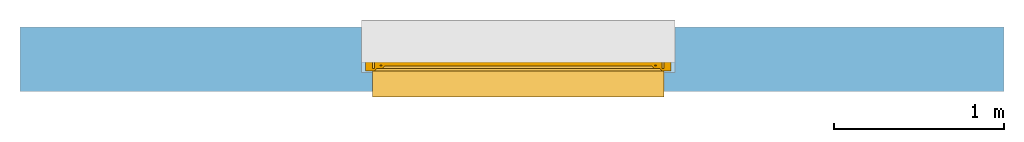
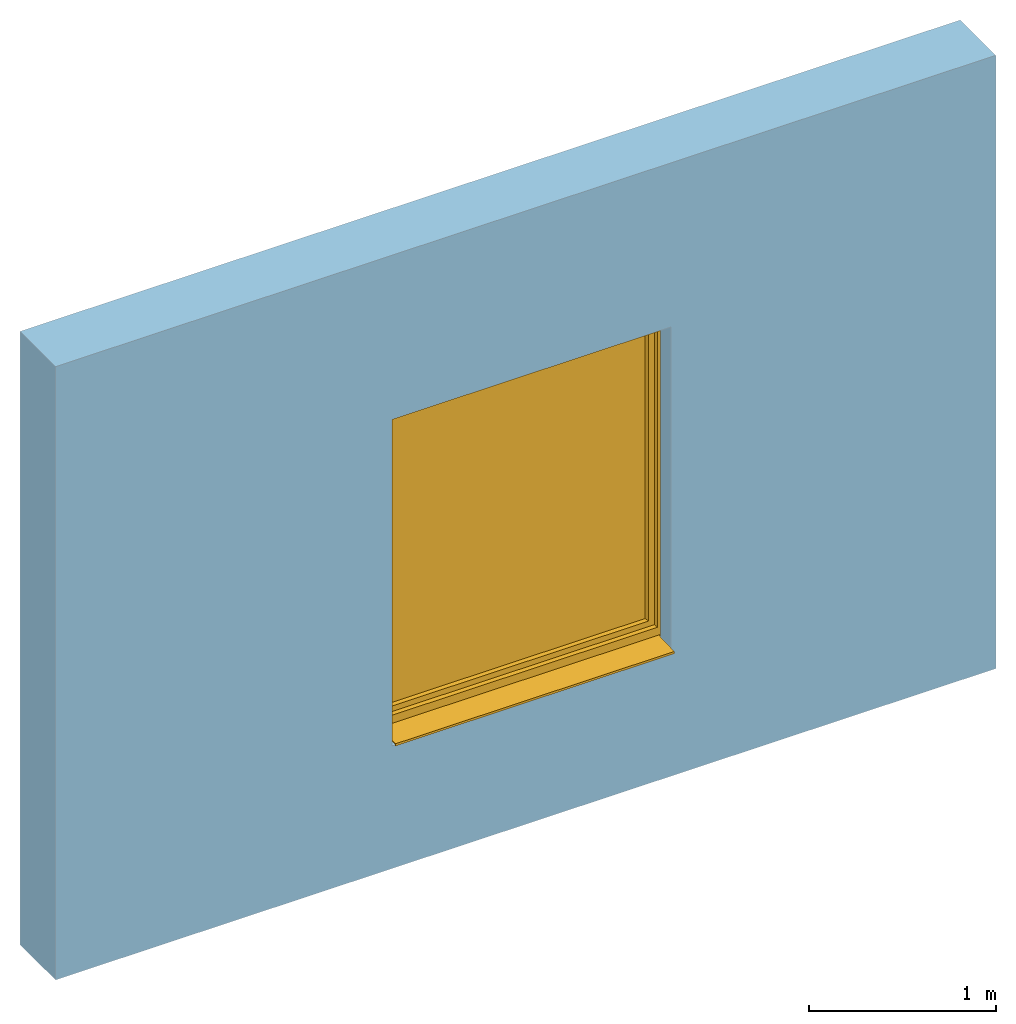
# One storey, part 2 of 3: 1 window, 1 opening, plus 1 element that does not belong to this part.
"""IFC2X3 building model written with IfcOpenShell, lengths in millimetres."""

from ifc_helpers import new_model, entity, si_unit, converted_unit, derived_unit, direction, frame, frame_2d, origin, place, context, subcontext, project, spatial, rectangle, extrude, faceted_brep, source, transform, mapped, material, material_list, layer, layer_set, layer_usage, type_object, type_shapes, element, fill, save


model = new_model("IFC2X3")

# Units and contexts
model_context = context("Model", 3, precision=0.01, world=origin(), true_north=direction((6.12303176911189e-17, 1.0)))
context_of_model = context(None, 3, precision=0.01, world=origin(), true_north=direction((6.12303176911189e-17, 1.0)))
body_context = subcontext(model_context, "Body", "Model", "MODEL_VIEW")
ifc_project = project(units=[si_unit("LENGTHUNIT", "METRE", prefix="MILLI"), si_unit("AREAUNIT", "SQUARE_METRE"), si_unit("VOLUMEUNIT", "CUBIC_METRE"), converted_unit("PLANEANGLEUNIT", "DEGREE", entity("IfcRatioMeasure", 0.0174532925199433), si_unit("PLANEANGLEUNIT", "RADIAN"), dimensions=[0, 0, 0, 0, 0, 0, 0]), si_unit("MASSUNIT", "GRAM", prefix="KILO"), si_unit("TIMEUNIT", "SECOND"), si_unit("FREQUENCYUNIT", "HERTZ"), si_unit("THERMODYNAMICTEMPERATUREUNIT", "DEGREE_CELSIUS"), derived_unit("THERMALTRANSMITTANCEUNIT", [(si_unit("MASSUNIT", "GRAM", prefix="KILO"), 1), (si_unit("THERMODYNAMICTEMPERATUREUNIT", "KELVIN"), -1), (si_unit("TIMEUNIT", "SECOND"), -3)]), derived_unit("VOLUMETRICFLOWRATEUNIT", [(si_unit("LENGTHUNIT", "METRE"), 3), (si_unit("TIMEUNIT", "SECOND"), -1)]), si_unit("ELECTRICCURRENTUNIT", "AMPERE"), si_unit("ELECTRICVOLTAGEUNIT", "VOLT"), si_unit("POWERUNIT", "WATT"), si_unit("FORCEUNIT", "NEWTON", prefix="KILO"), si_unit("ILLUMINANCEUNIT", "LUX"), si_unit("LUMINOUSFLUXUNIT", "LUMEN"), si_unit("LUMINOUSINTENSITYUNIT", "CANDELA"), si_unit("PRESSUREUNIT", "PASCAL")], contexts=[model_context, context_of_model])

# Site, building, storey
site_placement = place(None, origin())
site = spatial("IfcSite", under=ifc_project, at=site_placement, CompositionType="ELEMENT")
building_placement = place(site_placement, origin())
building = spatial("IfcBuilding", under=site, at=building_placement, CompositionType="ELEMENT")
storey_placement = place(building_placement, origin())
storey = spatial("IfcBuildingStorey", under=building, at=storey_placement, CompositionType="ELEMENT", Elevation=0.0)

# Wall, opening, window
ifc_material_1 = material()
ifc_layer = layer(ifc_material_1, 380.0)
ifc_layer_set = layer_set([ifc_layer])
ifc_layer_usage = layer_usage(ifc_layer_set, "AXIS2", "NEGATIVE", 190.0)
wall_type = type_object("IfcWallType", PredefinedType="STANDARD", material=ifc_layer_set)
wall_placement = place(storey_placement, frame((-18279.8270290102, 12543.5585138251, 0.0)))
wall = element("IfcWallStandardCase", 1, at=wall_placement, inside=storey, type_object=wall_type, material=ifc_layer_usage, context=body_context, shape_type="SweptSolid", body=[
    extrude(rectangle(XDim=5800.0, YDim=380.0, at=frame_2d((2900.0, 0.0), x_axis=(-1.0, 0.0))), origin(), (0.0, 0.0, 1.0), 4000.0),
])
opening_placement = place(wall_placement, frame((2011.78748304286, -570.0, 800.0)))
opening = element("IfcOpeningElement", 2, at=opening_placement, cuts=wall, ObjectType="Opening", context=body_context, shape_type="Brep", body=[
    faceted_brep([(1850.0, 1490.0, 2195.0), (1850.0, 1490.0, 0.0), (0.0, 1490.0, 0.0), (0.0, 1490.0, 2195.0), (1850.0, 490.0, 2195.0), (0.0, 490.0, 2195.0), (0.0, 490.0, 0.0), (65.0, 490.0, 0.0), (65.0, 490.0, 2130.0), (1785.0, 490.0, 2130.0), (1785.0, 490.0, 0.0), (1850.0, 490.0, 0.0), (1785.0, 0.0, 0.0), (65.0, 0.0, 0.0), (1785.0, 0.0, 2130.0), (65.0, 0.0, 2130.0)], [[[0, 1, 2, 3]], [[4, 5, 6, 7, 8, 9, 10, 11]], [[3, 5, 4, 0]], [[2, 6, 5, 3]], [[1, 11, 10, 12, 13, 7, 6, 2]], [[0, 4, 11, 1]], [[14, 15, 13, 12]], [[14, 9, 8, 15]], [[15, 8, 7, 13]], [[12, 10, 9, 14]]]),
])
ifc_material_2 = material()
ifc_material_3 = material()
ifc_material_4 = material()
ifc_material_5 = material()
ifc_material_list_1 = material_list([ifc_material_2, ifc_material_3, ifc_material_4, ifc_material_5])
ifc_material_list_2 = material_list([ifc_material_2, ifc_material_3, ifc_material_4, ifc_material_5])
window_style = type_object("IfcWindowStyle", ConstructionType="NOTDEFINED", OperationType="NOTDEFINED", ParameterTakesPrecedence=False, Sizeable=False, material=ifc_material_list_2)
shared_shape = source(origin(), body_context, "Body", "Brep", [
    faceted_brep([(1766.0, 895.0, 1128.0), (1766.0, 895.0, 1092.0), (1766.0, 903.0, 1092.0), (1766.0, 903.0, 1128.0), (1765.15676402479, 903.0, 1132.78534851353), (1765.57778161414, 895.0, 1130.39432433823), (1760.86155337324, 895.0, 1138.56228263261), (1759.00202746121, 903.0, 1140.12318487166), (1758.99898619598, 895.0, 1140.12494091649), (1743.13844662676, 903.0, 1138.56228263261), (1744.9979725388, 895.0, 1140.12318487166), (1745.00101380402, 903.0, 1140.12494091649), (1762.7263777273, 903.0, 1136.99693396949), (1762.7241205505, 895.0, 1136.99962434874), (1763.9398418894, 895.0, 1134.89413651259), (1754.432995843, 903.0, 1141.78696961729), (1754.42953736881, 895.0, 1141.78757948929), (1756.7142617824, 895.0, 1140.95626020289), (1760.86420259425, 903.0, 1138.56005942058), (1765.15556322829, 895.0, 1132.78864867645), (1763.94157087605, 903.0, 1134.89114124151), (1756.7175116521, 903.0, 1140.95507724448), (1749.57046263119, 903.0, 1141.78757948929), (1749.567004157, 895.0, 1141.78696961729), (1751.99827076291, 895.0, 1141.78727455329), (1747.2824883479, 895.0, 1140.95507724448), (1747.2857382176, 903.0, 1140.95626020289), (1740.05842912395, 895.0, 1134.89114124151), (1738.84443677171, 903.0, 1132.78864867645), (1738.84323597521, 895.0, 1132.78534851353), (1741.2758794495, 903.0, 1136.99962434874), (1741.2736222727, 895.0, 1136.99693396949), (1743.13579740575, 895.0, 1138.56005942058), (1752.0017292371, 903.0, 1141.78727455329), (1738.0, 895.0, 1128.0), (1738.42221838586, 903.0, 1130.39432433823), (1738.0, 903.0, 1128.0), (1740.06015811061, 903.0, 1134.89413651259), (1738.0, 895.0, 1092.0), (1738.0, 903.0, 1092.0), (1738.84323597521, 895.0, 1087.21465148645), (1738.84323597521, 903.0, 1087.21465148645), (1744.9979725388, 895.0, 1079.87681512831), (1743.13579740575, 895.0, 1081.4399405794), (1741.2736222727, 895.0, 1083.00306603049), (1741.2736222727, 903.0, 1083.00306603049), (1743.13579740575, 903.0, 1081.4399405794), (1744.9979725388, 903.0, 1079.87681512831), (1765.57778161414, 895.0, 1089.60567566175), (1765.15556322829, 895.0, 1087.21135132352), (1765.15556322829, 903.0, 1087.21135132352), (1765.56908263974, 903.0, 1089.55634534637), (1740.05842912395, 903.0, 1085.10885875847), (1740.05842912395, 895.0, 1085.10885875847), (1747.2824883479, 903.0, 1079.0449227555), (1749.567004157, 903.0, 1078.21303038269), (1749.567004157, 895.0, 1078.21303038269), (1747.2824883479, 895.0, 1079.0449227555), (1754.42953736881, 895.0, 1078.21242051068), (1751.9982707629, 895.0, 1078.21272544669), (1751.9982707629, 903.0, 1078.21272544669), (1754.42953736881, 903.0, 1078.21242051068), (1756.7142617824, 903.0, 1079.04373979708), (1758.99898619598, 903.0, 1079.87505908348), (1758.99898619598, 895.0, 1079.87505908348), (1756.7142617824, 895.0, 1079.04373979708), (1760.86155337324, 903.0, 1081.43771736736), (1762.7241205505, 903.0, 1083.00037565124), (1762.7241205505, 895.0, 1083.00037565124), (1760.86155337324, 895.0, 1081.43771736736), (1763.9398418894, 903.0, 1085.10586348738), (1763.9398418894, 895.0, 1085.10586348738), (1742.63603896932, 893.0, 1134.36396103068), (1741.75735931288, 893.0, 1132.24264068712), (1740.87867965644, 893.0, 1130.12132034356), (1740.0, 893.0, 1128.0), (1740.0, 893.0, 1092.0), (1740.87867965644, 893.0, 1089.87867965642), (1741.75735931288, 893.0, 1087.75735931286), (1742.63603896932, 893.0, 1085.6360389693), (1743.51471862576, 893.0, 1083.51471862574), (1745.63603896932, 893.0, 1082.6360389693), (1747.75735931288, 893.0, 1081.75735931286), (1749.87867965644, 893.0, 1080.87867965642), (1752.0, 893.0, 1080.0), (1754.12132034356, 893.0, 1080.87867965642), (1756.24264068712, 893.0, 1081.75735931286), (1758.36396103068, 893.0, 1082.6360389693), (1760.48528137424, 893.0, 1083.51471862574), (1761.36396103068, 893.0, 1085.6360389693), (1762.24264068712, 893.0, 1087.75735931286), (1763.12132034356, 893.0, 1089.87867965642), (1764.0, 893.0, 1092.0), (1764.0, 893.0, 1128.0), (1763.12132034356, 893.0, 1130.12132034356), (1762.24264068712, 893.0, 1132.24264068712), (1761.36396103068, 893.0, 1134.36396103068), (1760.48528137424, 893.0, 1136.48528137424), (1758.36396103068, 893.0, 1137.36396103068), (1756.24264068712, 893.0, 1138.24264068712), (1754.12132034356, 893.0, 1139.12132034356), (1752.0, 893.0, 1140.0), (1749.87867965644, 893.0, 1139.12132034356), (1747.75735931288, 893.0, 1138.24264068712), (1745.63603896932, 893.0, 1137.36396103068), (1743.51471862576, 893.0, 1136.48528137424), (1740.0, 905.0, 1128.0), (1740.87867965644, 905.0, 1130.12132034356), (1741.75735931288, 905.0, 1132.24264068712), (1742.63603896932, 905.0, 1134.36396103068), (1743.51471862576, 905.0, 1136.48528137424), (1745.63603896932, 905.0, 1137.36396103068), (1747.75735931288, 905.0, 1138.24264068712), (1749.87867965644, 905.0, 1139.12132034356), (1752.0, 905.0, 1140.0), (1754.12132034356, 905.0, 1139.12132034356), (1756.24264068712, 905.0, 1138.24264068712), (1758.36396103068, 905.0, 1137.36396103068), (1760.48528137424, 905.0, 1136.48528137424), (1761.36396103068, 905.0, 1134.36396103068), (1762.24264068712, 905.0, 1132.24264068712), (1763.12132034356, 905.0, 1130.12132034356), (1764.0, 905.0, 1128.0), (1764.0, 905.0, 1092.0), (1763.12132034356, 905.0, 1089.87867965642), (1762.24264068712, 905.0, 1087.75735931286), (1761.36396103068, 905.0, 1085.6360389693), (1760.48528137424, 905.0, 1083.51471862574), (1758.36396103068, 905.0, 1082.6360389693), (1756.24264068712, 905.0, 1081.75735931286), (1754.12132034356, 905.0, 1080.87867965642), (1752.0, 905.0, 1080.0), (1749.87867965644, 905.0, 1080.87867965642), (1747.75735931288, 905.0, 1081.75735931286), (1745.63603896932, 905.0, 1082.6360389693), (1743.51471862576, 905.0, 1083.51471862574), (1742.63603896932, 905.0, 1085.6360389693), (1741.75735931288, 905.0, 1087.75735931286), (1740.87867965644, 905.0, 1089.87867965642), (1740.0, 905.0, 1092.0)], [[[0, 1, 2, 3]], [[4, 5, 3]], [[6, 7, 8]], [[9, 10, 11]], [[12, 13, 14]], [[15, 16, 17]], [[7, 6, 18]], [[5, 0, 3]], [[18, 6, 13]], [[14, 19, 20]], [[4, 19, 5]], [[15, 17, 21]], [[8, 21, 17]], [[12, 14, 20]], [[22, 23, 24]], [[25, 11, 10]], [[26, 23, 22]], [[27, 28, 29]], [[21, 8, 7]], [[20, 19, 4]], [[30, 31, 32]], [[33, 16, 15]], [[34, 35, 36]], [[11, 25, 26]], [[23, 26, 25]], [[37, 27, 31]], [[32, 10, 9]], [[29, 28, 35]], [[30, 32, 9]], [[34, 29, 35]], [[28, 27, 37]], [[18, 13, 12]], [[33, 24, 16]], [[37, 31, 30]], [[22, 24, 33]], [[38, 34, 36, 39]], [[40, 38, 39, 41]], [[42, 43, 44, 45, 46, 47]], [[2, 1, 48, 49, 50, 51]], [[41, 52, 45, 44, 53, 40]], [[47, 54, 55, 56, 57, 42]], [[58, 59, 56, 55, 60, 61]], [[61, 62, 63, 64, 65, 58]], [[66, 67, 68, 69, 64, 63]], [[67, 70, 50, 49, 71, 68]], [[72, 73, 74, 75, 76, 77, 78, 79, 80, 81, 82, 83, 84, 85, 86, 87, 88, 89, 90, 91, 92, 93, 94, 95, 96, 97, 98, 99, 100, 101, 102, 103, 104, 105]], [[92, 48, 1]], [[48, 92, 91]], [[71, 49, 90]], [[44, 79, 53]], [[90, 49, 91]], [[78, 40, 53]], [[88, 68, 89]], [[88, 69, 68]], [[69, 87, 64]], [[89, 68, 71]], [[82, 57, 83]], [[91, 49, 48]], [[65, 85, 58]], [[82, 42, 57]], [[56, 84, 83]], [[65, 64, 86]], [[56, 83, 57]], [[76, 38, 77]], [[58, 84, 56, 59]], [[80, 44, 43]], [[85, 65, 86]], [[40, 77, 38]], [[82, 81, 42]], [[40, 78, 77]], [[43, 81, 80]], [[71, 90, 89]], [[87, 69, 88]], [[79, 44, 80]], [[79, 78, 53]], [[87, 86, 64]], [[85, 84, 58]], [[43, 42, 81]], [[92, 1, 0, 93]], [[72, 31, 27]], [[34, 74, 29]], [[27, 29, 73]], [[13, 96, 14]], [[74, 73, 29]], [[95, 19, 14]], [[104, 32, 105]], [[105, 32, 31]], [[32, 104, 10]], [[105, 31, 72]], [[99, 17, 100]], [[74, 34, 75]], [[25, 102, 23]], [[99, 8, 17]], [[16, 101, 100]], [[25, 10, 103]], [[16, 100, 17]], [[5, 93, 0]], [[99, 98, 8]], [[97, 13, 6]], [[93, 5, 94]], [[102, 25, 103]], [[94, 5, 19]], [[24, 23, 101, 16]], [[27, 73, 72]], [[96, 13, 97]], [[6, 98, 97]], [[96, 95, 14]], [[104, 103, 10]], [[102, 101, 23]], [[6, 8, 98]], [[94, 19, 95]], [[75, 34, 38, 76]], [[106, 107, 108, 109, 110, 111, 112, 113, 114, 115, 116, 117, 118, 119, 120, 121, 122, 123, 124, 125, 126, 127, 128, 129, 130, 131, 132, 133, 134, 135, 136, 137, 138, 139]], [[136, 45, 52]], [[39, 138, 41]], [[52, 41, 137]], [[67, 126, 70]], [[138, 137, 41]], [[125, 50, 70]], [[134, 46, 135]], [[135, 46, 45]], [[46, 134, 47]], [[135, 45, 136]], [[129, 62, 130]], [[138, 39, 139]], [[54, 132, 55]], [[129, 63, 62]], [[61, 131, 130]], [[54, 47, 133]], [[61, 130, 62]], [[51, 123, 2]], [[129, 128, 63]], [[127, 67, 66]], [[123, 51, 124]], [[132, 54, 133]], [[124, 51, 50]], [[60, 55, 131, 61]], [[52, 137, 136]], [[126, 67, 127]], [[66, 128, 127]], [[126, 125, 70]], [[134, 133, 47]], [[132, 131, 55]], [[66, 63, 128]], [[124, 50, 125]], [[122, 3, 2, 123]], [[119, 12, 20]], [[3, 121, 4]], [[20, 4, 120]], [[30, 109, 37]], [[121, 120, 4]], [[108, 28, 37]], [[117, 18, 118]], [[118, 18, 12]], [[18, 117, 7]], [[118, 12, 119]], [[112, 26, 113]], [[121, 3, 122]], [[21, 115, 15]], [[112, 11, 26]], [[22, 114, 113]], [[21, 7, 116]], [[22, 113, 26]], [[35, 106, 36]], [[112, 111, 11]], [[110, 30, 9]], [[106, 35, 107]], [[115, 21, 116]], [[107, 35, 28]], [[33, 15, 114, 22]], [[20, 120, 119]], [[109, 30, 110]], [[9, 111, 110]], [[109, 108, 37]], [[117, 116, 7]], [[115, 114, 15]], [[9, 11, 111]], [[107, 28, 108]], [[139, 39, 36, 106]]]),
    faceted_brep([(1746.70849737789, 844.723224744637, 1050.52114796614), (1757.29150262215, 844.723224744635, 1050.52114796615), (1757.29150262215, 849.16211476527, 1092.66882878316), (1746.70849737789, 849.162114765271, 1092.66882878316), (1759.48331477357, 853.551651869381, 1050.52114796614), (1759.48331477357, 857.796844327507, 1090.82965209671), (1752.0, 858.723224744636, 1050.52114796614), (1752.0, 862.854951797642, 1089.75228733739), (1744.51668522647, 853.551651869382, 1050.52114796614), (1744.51668522647, 857.796844327508, 1090.82965209671), (1746.70849737789, 849.162114765271, 1008.37346714913), (1757.29150262215, 849.162114765269, 1008.37346714913), (1759.48331477357, 857.796844327506, 1010.21264383558), (1752.0, 862.854951797641, 1011.2900085949), (1744.51668522647, 857.796844327507, 1010.21264383558)], [[[0, 1, 2, 3]], [[1, 4, 5, 2]], [[4, 6, 7, 5]], [[6, 8, 9, 7]], [[8, 0, 3, 9]], [[10, 11, 1, 0]], [[11, 12, 4, 1]], [[12, 13, 6, 4]], [[13, 14, 8, 6]], [[14, 10, 0, 8]], [[3, 2, 5, 7, 9]], [[14, 13, 12, 11, 10]]]),
    faceted_brep([(1742.05108068303, 893.0, 1110.94591729899), (1742.6116955587, 893.0, 1113.43924096905), (1743.78926206305, 893.0, 1115.70333478469), (1745.50517385399, 893.0, 1117.59726390533), (1747.64110105648, 893.0, 1119.0), (1752.0, 893.0, 1119.0), (1756.35889894356, 893.0, 1119.0), (1758.49482614605, 893.0, 1117.59726390533), (1760.21073793698, 893.0, 1115.70333478469), (1761.38830444134, 893.0, 1113.43924096905), (1761.94891931701, 893.0, 1110.94591729899), (1761.86909546584, 893.0, 1108.39192032138), (1761.13720137139, 893.0, 1105.94604186492), (1759.80945551189, 893.0, 1103.76141304128), (1757.97703479258, 893.0, 1101.98307257926), (1755.74800577773, 893.0, 1100.73512735944), (1753.27629940962, 893.0, 1100.08403873225), (1750.72370059042, 893.0, 1100.08403873225), (1748.25199422231, 893.0, 1100.73512735944), (1746.02296520745, 893.0, 1101.98307257926), (1744.19054448815, 893.0, 1103.76141304128), (1742.86279862864, 893.0, 1105.94604186492), (1742.13090453419, 893.0, 1108.39192032138), (1745.36991581395, 850.428800129017, 1091.81582813481), (1744.45534262368, 851.933218860195, 1090.80273507334), (1744.03032959918, 853.579532805258, 1089.69408812539), (1744.11827066873, 855.263398076631, 1088.5601536778), (1744.7119819839, 856.873838872368, 1087.47566412561), (1745.77997796969, 858.307181915726, 1086.51043425852), (1747.2448781787, 859.474223513841, 1085.72453488024), (1749.01896983583, 860.293497882239, 1085.17282599702), (1750.98499562504, 860.719017712997, 1084.88627599659), (1753.01500437499, 860.719017712997, 1084.88627599659), (1754.9810301642, 860.293497882239, 1085.17282599702), (1756.75512182133, 859.474223513841, 1085.72453488024), (1758.22002203034, 858.307181915725, 1086.51043425852), (1759.28801801613, 856.873838872367, 1087.47566412561), (1759.88172933131, 855.26339807663, 1088.5601536778), (1759.96967040085, 853.579532805258, 1089.69408812539), (1759.54465737635, 851.933218860195, 1090.80273507334), (1758.63008418608, 850.428800129017, 1091.81582813481), (1757.29150262215, 849.161332807104, 1092.66935536288), (1753.79310555172, 849.161332807104, 1092.66935536288), (1750.2508014648, 849.161332807105, 1092.66935536288), (1746.70849737789, 849.161332807105, 1092.66935536288), (1754.52949888047, 863.583676958992, 1108.5347916618), (1752.0, 866.407496256042, 1110.46960324717), (1752.02195286218, 856.06904422149, 1101.86725150296), (1757.17259060864, 853.432156174798, 1097.74862550588), (1754.75377578685, 855.997000236909, 1101.79007956709), (1749.62092495289, 862.432874221678, 1107.66721198753), (1749.76284265702, 870.821838386956, 1113.00337884313), (1747.01936527075, 860.32641042986, 1105.94792966368), (1749.15805318919, 855.078190113582, 1100.77853435748), (1750.96832520456, 879.059260831814, 1116.41174131505), (1747.33023316361, 875.432522578079, 1115.10298096759), (1754.09205911857, 883.083385469991, 1117.54270145075), (1756.98063472928, 860.32641042986, 1105.94792966368), (1756.66976683642, 875.432522578079, 1115.10298096759), (1760.33445262989, 860.924208850645, 1095.92276589619), (1760.86792617061, 873.480157500358, 1108.07942490607), (1761.45909914595, 882.759427033562, 1110.08550854291), (1755.91403231325, 864.739374449817, 1090.68801313959), (1757.61971635533, 869.555744991712, 1095.78506579301), (1745.02520991073, 866.744726380615, 1095.70424775684), (1742.98228348089, 874.898493111577, 1108.22389640407), (1745.18111717899, 877.977562710016, 1100.92399318818), (1758.84403415027, 880.582594774287, 1101.67364545899), (1760.7354074063, 866.455644046918, 1102.17506192795), (1742.69314957983, 883.881036137867, 1106.84627828436), (1749.47019846674, 885.315312440967, 1099.97313305254)], [[[0, 1, 2, 3, 4, 5, 6, 7, 8, 9, 10, 11, 12, 13, 14, 15, 16, 17, 18, 19, 20, 21, 22]], [[23, 24, 25, 26, 27, 28, 29, 30, 31, 32, 33, 34, 35, 36, 37, 38, 39, 40, 41, 42, 43, 44]], [[45, 46, 47]], [[42, 41, 48]], [[49, 45, 47]], [[50, 46, 51]], [[50, 51, 52]], [[43, 47, 53]], [[53, 50, 52]], [[54, 4, 55]], [[44, 43, 53]], [[56, 6, 5]], [[48, 49, 42]], [[42, 47, 43]], [[49, 48, 57]], [[5, 54, 56]], [[49, 57, 45]], [[42, 49, 47]], [[57, 58, 45]], [[58, 46, 45]], [[50, 47, 46]], [[44, 53, 52]], [[47, 50, 53]], [[46, 54, 51]], [[56, 46, 58]], [[4, 54, 5]], [[54, 55, 51]], [[52, 51, 55]], [[46, 56, 54]], [[6, 56, 58]], [[40, 59, 41]], [[39, 38, 59]], [[59, 40, 39]], [[36, 59, 37]], [[60, 61, 58]], [[35, 34, 62]], [[62, 59, 36]], [[59, 62, 63]], [[33, 62, 34]], [[35, 62, 36]], [[38, 37, 59]], [[9, 8, 61]], [[61, 10, 9]], [[64, 65, 66]], [[8, 7, 61]], [[58, 7, 6]], [[58, 61, 7]], [[63, 67, 68]], [[67, 13, 61]], [[52, 55, 65]], [[67, 60, 68]], [[31, 62, 32]], [[59, 68, 57]], [[13, 67, 14]], [[65, 69, 66]], [[10, 61, 11]], [[11, 61, 12]], [[69, 55, 1]], [[16, 70, 17]], [[33, 32, 62]], [[66, 67, 63]], [[69, 70, 66]], [[67, 66, 70]], [[70, 15, 67]], [[29, 64, 30]], [[27, 64, 28]], [[64, 29, 28]], [[65, 64, 52]], [[25, 24, 64]], [[57, 60, 58]], [[64, 24, 52]], [[23, 44, 52]], [[67, 61, 60]], [[23, 52, 24]], [[64, 26, 25]], [[69, 65, 55]], [[63, 64, 66]], [[69, 20, 19]], [[69, 21, 20]], [[61, 13, 12]], [[60, 57, 68]], [[70, 16, 15]], [[17, 70, 18]], [[68, 59, 63]], [[62, 64, 63]], [[19, 18, 70]], [[69, 1, 0]], [[0, 22, 69]], [[1, 55, 2]], [[30, 62, 31]], [[64, 27, 26]], [[3, 2, 55]], [[4, 3, 55]], [[19, 70, 69]], [[15, 14, 67]], [[21, 69, 22]], [[59, 57, 48, 41]], [[64, 62, 30]]]),
    faceted_brep([(1773.0, 975.0, 2118.0), (1773.0, 920.0, 2118.0), (1773.0, 920.0, 102.0), (1773.0, 975.0, 102.0), (1712.00008196447, 960.0, 2057.00008196445), (1724.0, 975.0, 2069.0), (1724.0, 975.0, 151.0), (1712.00008196447, 960.0, 162.999918035509), (1740.0, 918.0, 2085.0), (1740.0, 960.0, 2085.0), (1740.0, 960.0, 135.0), (1740.0, 918.0, 135.0), (1724.0, 906.0, 2069.0), (1712.0, 918.0, 2057.0), (1712.0, 918.0, 163.0), (1724.0, 906.0, 151.0), (1737.0, 905.0, 2082.0), (1737.0, 906.0, 2082.0), (1737.0, 906.0, 138.0), (1737.0, 905.0, 138.0), (1793.0, 907.0, 2138.0), (1791.0, 905.0, 2136.0), (1791.0, 905.0, 84.0), (1793.0, 907.0, 82.0), (1793.0, 920.0, 2138.0), (1793.0, 920.0, 82.0), (77.0, 920.0, 102.0), (77.0, 975.0, 102.0), (126.0, 975.0, 151.0), (137.999918035533, 960.0, 162.999918035509), (110.0, 960.0, 135.0), (110.0, 918.0, 135.0), (138.0, 918.0, 163.0), (126.0, 906.0, 151.0), (113.0, 906.0, 138.0), (113.0, 905.0, 138.0), (59.0, 905.0, 84.0), (57.0, 907.0, 82.0), (57.0, 920.0, 82.0), (77.0, 920.0, 2118.0), (77.0, 975.0, 2118.0), (126.0, 975.0, 2069.0), (137.999918035533, 960.0, 2057.00008196445), (110.0, 960.0, 2085.0), (110.0, 918.0, 2085.0), (138.0, 918.0, 2057.0), (126.0, 906.0, 2069.0), (113.0, 906.0, 2082.0), (113.0, 905.0, 2082.0), (59.0, 905.0, 2136.0), (57.0, 907.0, 2138.0), (57.0, 920.0, 2138.0)], [[[0, 1, 2, 3]], [[4, 5, 6, 7]], [[8, 9, 10, 11]], [[12, 13, 14, 15]], [[16, 17, 18, 19]], [[20, 21, 22, 23]], [[24, 20, 23, 25]], [[3, 2, 26, 27]], [[7, 6, 28, 29]], [[11, 10, 30, 31]], [[15, 14, 32, 33]], [[19, 18, 34, 35]], [[23, 22, 36, 37]], [[25, 23, 37, 38]], [[27, 26, 39, 40]], [[29, 28, 41, 42]], [[31, 30, 43, 44]], [[33, 32, 45, 46]], [[35, 34, 47, 48]], [[37, 36, 49, 50]], [[38, 37, 50, 51]], [[40, 39, 1, 0]], [[3, 27, 40, 0], [5, 41, 28, 6]], [[42, 41, 5, 4]], [[7, 29, 42, 4], [9, 43, 30, 10]], [[44, 43, 9, 8]], [[11, 31, 44, 8], [13, 45, 32, 14]], [[46, 45, 13, 12]], [[15, 33, 46, 12], [17, 47, 34, 18]], [[48, 47, 17, 16]], [[19, 35, 48, 16], [21, 49, 36, 22]], [[50, 49, 21, 20]], [[51, 50, 20, 24]], [[1, 39, 26, 2], [25, 38, 51, 24]]], outer=[[True], [True], [True], [True], [True], [True], [True], [True], [True], [True], [True], [True], [True], [True], [True], [True], [True], [True], [True], [True], [True], [True], [True, False], [True], [False, True], [True], [True, False], [True], [False, True], [True], [False, True], [True], [True], [False, True]]),
    faceted_brep([(122.0, 918.0, 2073.0), (122.0, 918.0, 147.0), (1728.0, 918.0, 147.0), (1728.0, 918.0, 2073.0), (122.0, 960.0, 2073.0), (1728.0, 960.0, 2073.0), (1728.0, 960.0, 147.0), (122.0, 960.0, 147.0)], [[[0, 1, 2, 3]], [[4, 5, 6, 7]], [[1, 0, 4, 7]], [[2, 1, 7, 6]], [[3, 2, 6, 5]], [[0, 3, 5, 4]]]),
    faceted_brep([(110.0, 923.0, 135.0), (110.0, 955.0, 135.0), (1740.0, 955.0, 135.0), (1740.0, 923.0, 135.0), (138.0, 928.0, 163.0), (138.0, 923.0, 163.0), (1712.0, 923.0, 163.0), (1712.0, 928.0, 163.0), (122.0, 950.0, 147.0), (122.0, 928.0, 147.0), (1728.0, 928.0, 147.0), (1728.0, 950.0, 147.0), (138.0, 955.0, 163.0), (138.0, 950.0, 163.0), (1712.0, 950.0, 163.0), (1712.0, 955.0, 163.0), (1740.0, 955.0, 2085.0), (1740.0, 923.0, 2085.0), (1712.0, 923.0, 2057.0), (1712.0, 928.0, 2057.0), (1728.0, 928.0, 2073.0), (1728.0, 950.0, 2073.0), (1712.0, 950.0, 2057.0), (1712.0, 955.0, 2057.0), (110.0, 955.0, 2085.0), (110.0, 923.0, 2085.0), (138.0, 923.0, 2057.0), (138.0, 928.0, 2057.0), (122.0, 928.0, 2073.0), (122.0, 950.0, 2073.0), (138.0, 950.0, 2057.0), (138.0, 955.0, 2057.0)], [[[0, 1, 2, 3]], [[4, 5, 6, 7]], [[8, 9, 10, 11]], [[12, 13, 14, 15]], [[3, 2, 16, 17]], [[7, 6, 18, 19]], [[11, 10, 20, 21]], [[15, 14, 22, 23]], [[17, 16, 24, 25]], [[19, 18, 26, 27]], [[21, 20, 28, 29]], [[23, 22, 30, 31]], [[15, 23, 31, 12], [1, 24, 16, 2]], [[25, 24, 1, 0]], [[3, 17, 25, 0], [5, 26, 18, 6]], [[27, 26, 5, 4]], [[7, 19, 27, 4], [9, 28, 20, 10]], [[29, 28, 9, 8]], [[11, 21, 29, 8], [13, 30, 22, 14]], [[31, 30, 13, 12]]], outer=[[True], [True], [True], [True], [True], [True], [True], [True], [True], [True], [True], [True], [False, True], [True], [True, False], [True], [False, True], [True], [True, False], [True]]),
    faceted_brep([(1820.0, 970.0, 50.0), (1820.0, 970.0, 25.0), (30.0, 970.0, 25.0), (30.0, 970.0, 50.0), (1820.0, 940.0, 50.0), (30.0, 940.0, 50.0), (30.0, 940.0, 25.0), (1820.0, 940.0, 25.0)], [[[0, 1, 2, 3]], [[4, 5, 6, 7]], [[5, 4, 0, 3]], [[6, 5, 3, 2]], [[7, 6, 2, 1]], [[4, 7, 1, 0]]]),
    faceted_brep([(1825.0, 990.0, 2170.0), (1825.0, 920.0, 2170.0), (1825.0, 920.0, 50.0), (1825.0, 990.0, 50.0), (1785.0, 920.0, 90.0), (65.0, 920.0, 90.0), (65.0, 920.0, 2130.0), (1785.0, 920.0, 2130.0), (25.0, 920.0, 2170.0), (25.0, 920.0, 50.0), (25.0, 990.0, 50.0), (25.0, 990.0, 2170.0), (1772.0, 990.0, 2117.0), (78.0, 990.0, 2117.0), (78.0, 990.0, 103.0), (1772.0, 990.0, 103.0), (1760.0, 975.0, 2105.0), (1760.0, 975.0, 115.0), (90.0, 975.0, 115.0), (90.0, 975.0, 2105.0), (1785.0, 975.0, 2130.0), (65.0, 975.0, 2130.0), (65.0, 975.0, 90.0), (1785.0, 975.0, 90.0)], [[[0, 1, 2, 3]], [[4, 5, 6, 7], [1, 8, 9, 2]], [[3, 2, 9, 10]], [[3, 10, 11, 0], [12, 13, 14, 15]], [[16, 12, 15, 17]], [[17, 15, 14, 18]], [[17, 18, 19, 16], [20, 21, 22, 23]], [[7, 20, 23, 4]], [[4, 23, 22, 5]], [[10, 9, 8, 11]], [[18, 14, 13, 19]], [[5, 22, 21, 6]], [[11, 8, 1, 0]], [[19, 13, 12, 16]], [[6, 21, 20, 7]]], outer=[[True], [False, True], [True], [True, False], [True], [True], [False, True], [True], [True], [True], [True], [True], [True], [True], [True]]),
    faceted_brep([(1785.0, 970.0, 40.6149556546776), (1785.0, 970.0, 30.0), (1785.0, 1140.0, 30.0), (1785.0, 1140.0, 20.2340936757366), (1785.0, 1145.0, 20.2340936757366), (1785.0, 1145.0, 34.5038209936144), (65.0, 970.0, 40.6149556546776), (65.0, 1145.0, 34.5038209936144), (65.0, 1145.0, 20.2340936757366), (65.0, 1140.0, 20.2340936757366), (65.0, 1140.0, 30.0), (65.0, 970.0, 30.0)], [[[0, 1, 2, 3, 4, 5]], [[6, 7, 8, 9, 10, 11]], [[1, 0, 6, 11]], [[2, 1, 11, 10]], [[3, 2, 10, 9]], [[4, 3, 9, 8]], [[5, 4, 8, 7]], [[0, 5, 7, 6]]]),
])
type_shapes(window_style, [shared_shape])
window_placement = place(opening_placement, frame((1850.0, 1490.0, 0.0), z_axis=(0.0, 0.0, 1.0), x_axis=(-1.0, 0.0, 0.0)))
window = element("IfcWindow", 3, at=window_placement, inside=storey, type_object=window_style, material=ifc_material_list_1, OverallHeight=2195.00000000001, OverallWidth=1850.0, context=body_context, shape_type="MappedRepresentation", body=[
    mapped(shared_shape, transform((0.0, 0.0, 0.0), scale=1.0)),
])
fill(opening, window)

save(model, "model.ifc")
